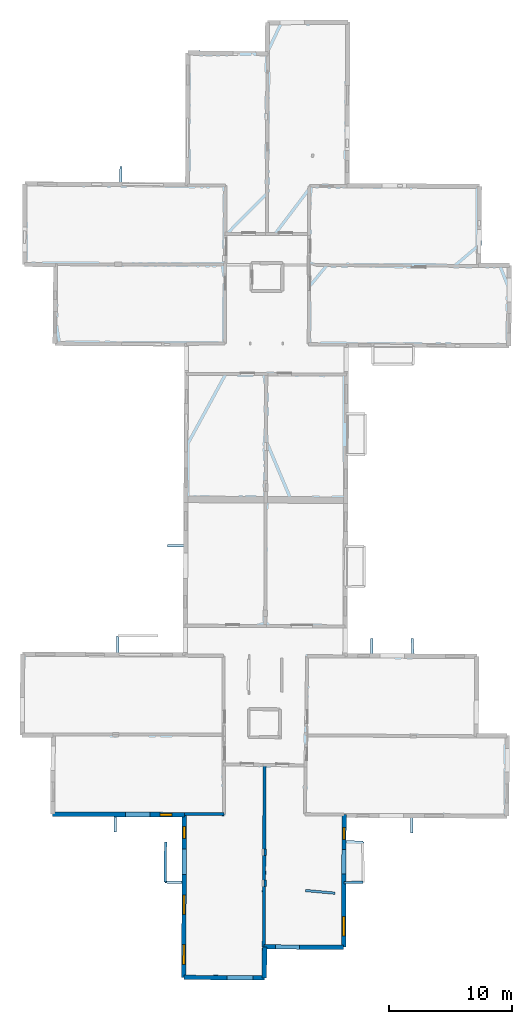
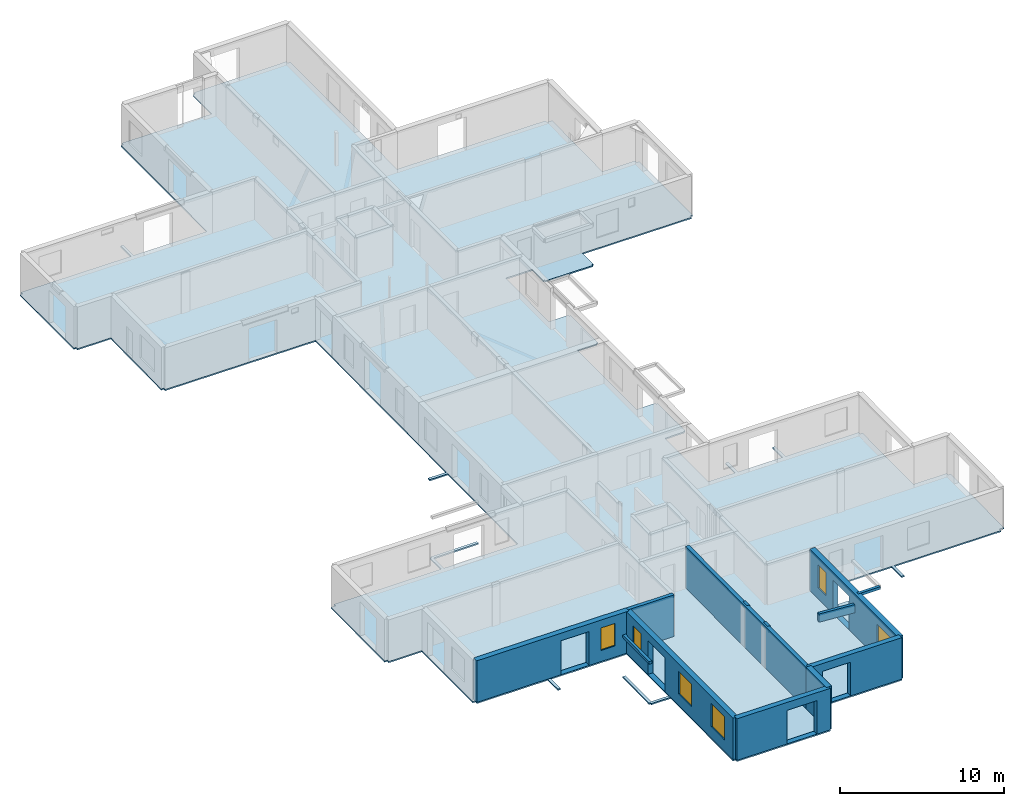
# One storey, part 3 of 15: 13 walls, 6 windows, 1 slab, 11 openings.
"""IFC2X3 building model written with IfcOpenShell, lengths in metres."""

from ifc_helpers import new_model, entity, si_unit, converted_unit, derived_unit, direction, frame, frame_2d, origin, origin_2d_with_axis, place, context, subcontext, project, spatial, polyline, rectangle, outline, extrude, source, transform, mapped, material, layer, layer_set, layer_usage, type_object, type_shapes, element, fill, save


model = new_model("IFC2X3")

# Units and contexts
model_context = context("Model", 3, precision=1e-05, world=origin(), true_north=direction((0.0, 1.0)))
body_context = subcontext(model_context, "Body", "Model", "MODEL_VIEW")
ifc_project = project(units=[si_unit("LENGTHUNIT", "METRE"), si_unit("AREAUNIT", "SQUARE_METRE"), si_unit("VOLUMEUNIT", "CUBIC_METRE"), converted_unit("PLANEANGLEUNIT", "DEGREE", entity("IfcRatioMeasure", 0.0174532925199433), si_unit("PLANEANGLEUNIT", "RADIAN"), dimensions=[0, 0, 0, 0, 0, 0, 0]), si_unit("MASSUNIT", "GRAM", prefix="KILO"), derived_unit("MASSDENSITYUNIT", [(si_unit("MASSUNIT", "GRAM", prefix="KILO"), 1), (si_unit("LENGTHUNIT", "METRE"), -3)]), derived_unit("MOMENTOFINERTIAUNIT", [(si_unit("LENGTHUNIT", "METRE"), 4)]), si_unit("TIMEUNIT", "SECOND"), si_unit("FREQUENCYUNIT", "HERTZ"), si_unit("THERMODYNAMICTEMPERATUREUNIT", "DEGREE_CELSIUS"), derived_unit("THERMALTRANSMITTANCEUNIT", [(si_unit("MASSUNIT", "GRAM", prefix="KILO"), 1), (si_unit("THERMODYNAMICTEMPERATUREUNIT", "KELVIN"), -1), (si_unit("TIMEUNIT", "SECOND"), -3)]), derived_unit("VOLUMETRICFLOWRATEUNIT", [(si_unit("LENGTHUNIT", "METRE"), 3), (si_unit("TIMEUNIT", "SECOND"), -1)]), si_unit("ELECTRICCURRENTUNIT", "AMPERE"), si_unit("ELECTRICVOLTAGEUNIT", "VOLT"), si_unit("POWERUNIT", "WATT"), si_unit("FORCEUNIT", "NEWTON", prefix="KILO"), si_unit("ILLUMINANCEUNIT", "LUX"), si_unit("LUMINOUSFLUXUNIT", "LUMEN"), si_unit("LUMINOUSINTENSITYUNIT", "CANDELA"), derived_unit("USERDEFINED", [(si_unit("MASSUNIT", "GRAM", prefix="KILO"), -1), (si_unit("LENGTHUNIT", "METRE"), -2), (si_unit("TIMEUNIT", "SECOND"), 3), (si_unit("LUMINOUSFLUXUNIT", "LUMEN"), 1)]), derived_unit("LINEARVELOCITYUNIT", [(si_unit("LENGTHUNIT", "METRE"), 1), (si_unit("TIMEUNIT", "SECOND"), -1)]), si_unit("PRESSUREUNIT", "PASCAL"), derived_unit("USERDEFINED", [(si_unit("LENGTHUNIT", "METRE"), -2), (si_unit("MASSUNIT", "GRAM", prefix="KILO"), 1), (si_unit("TIMEUNIT", "SECOND"), -2)]), derived_unit("LINEARFORCEUNIT", [(si_unit("MASSUNIT", "GRAM", prefix="KILO"), 1), (si_unit("LENGTHUNIT", "METRE"), 1), (si_unit("TIMEUNIT", "SECOND"), -2), (si_unit("LENGTHUNIT", "METRE"), -1)]), derived_unit("PLANARFORCEUNIT", [(si_unit("MASSUNIT", "GRAM", prefix="KILO"), 1), (si_unit("LENGTHUNIT", "METRE"), 1), (si_unit("TIMEUNIT", "SECOND"), -2), (si_unit("LENGTHUNIT", "METRE"), -2)])], contexts=[model_context])

# Site, building, storey
placement_1 = place(None, origin())
site = spatial("IfcSite", under=ifc_project, at=placement_1, CompositionType="ELEMENT")
building = spatial("IfcBuilding", under=site, at=placement_1, CompositionType="ELEMENT")
storey_placement = place(placement_1, frame((0.0, 0.0, 2.3807327747345)))
storey = spatial("IfcBuildingStorey", under=building, at=storey_placement, Name="Level 2", CompositionType="ELEMENT", Elevation=2.3807327747345)

# Slab
ifc_material_1 = material(Name="Floor default")
ifc_layer_1 = layer(ifc_material_1, 0.1)
ifc_layer_set_1 = layer_set([ifc_layer_1], Name="Floor : 100mm")
ifc_layer_usage_1 = layer_usage(ifc_layer_set_1, "AXIS3", "POSITIVE", 0.0)
slab_type = type_object("IfcSlabType", Name="Floor : 100mm", PredefinedType="FLOOR")
slab_placement = place(storey_placement, origin())
element("IfcSlab", 1, at=slab_placement, inside=storey, type_object=slab_type, material=ifc_layer_usage_1, Name="Floor : 100mm", ObjectType="Floor : 100mm", PredefinedType="FLOOR", context=body_context, shape_type="SweptSolid", body=[
    extrude(outline(polyline([(-13.683331489563, 19.4474563598633), (-13.5033340454102, 19.4465980529785), (-13.5040082931519, 19.2665996551514), (-11.1743402481079, 19.2578716278076), (-11.2043762207031, 13.0245876312256), (-11.0243797302246, 13.023720741272), (-11.0250949859619, 12.833722114563), (-6.06487083435059, 12.8150625228882), (-6.06035614013672, 11.5717830657959), (-5.8603572845459, 11.572509765625), (-5.86486625671387, 12.8143100738525), (-0.51823616027832, 12.7941980361938), (-0.535752296447754, 7.60072088241577), (-1.79068851470947, 7.61459493637085), (-1.76200675964355, 10.7753887176514), (-1.96199798583984, 10.7772035598755), (-1.99158573150635, 7.51661109924316), (-1.8915901184082, 7.5157036781311), (-1.89269542694092, 7.41570997238159), (-0.536426544189453, 7.40071582794189), (-0.562169075012207, -0.232175529003143), (-0.382170677185059, -0.232782408595085), (-0.383003234863281, -0.412778675556183), (6.16565418243408, -0.443077743053436), (6.16648769378662, -0.263079524040222), (6.35148525238037, -0.263790488243103), (6.36043262481689, 2.06458950042725), (12.6045618057251, 2.03753018379211), (12.6053419113159, 2.21752667427063), (12.7853422164917, 2.21702480316162), (12.7997140884399, 7.37378740310669), (14.1824331283569, 7.38224840164185), (14.1818227767944, 7.48224592208862), (14.2818212509155, 7.48271894454956), (14.2663774490356, 10.74733543396), (14.1663789749146, 10.746862411499), (14.1691541671753, 10.8468246459961), (12.8094987869263, 10.8845558166504), (12.8146600723267, 12.7366809844971), (18.0459899902344, 12.7129278182983), (18.0380744934082, 11.4866056442261), (18.2380714416504, 11.485315322876), (18.2459869384766, 12.7120199203491), (25.7083015441895, 12.6781377792358), (25.7091217041016, 12.8581981658936), (26.0352439880371, 12.8565711975098), (26.0678863525391, 19.4015102386475), (25.8828926086426, 19.4024314880371), (25.8830604553223, 19.5874309539795), (23.5625038146973, 19.5895538330078), (23.5972633361816, 25.8405075073242), (23.4122657775879, 25.8415374755859), (23.413200378418, 26.0265350341797), (18.2958908081055, 26.0524444580078), (18.2884140014648, 27.2836627960205), (18.0884170532227, 27.2824478149414), (18.0958786010742, 26.0534572601318), (14.9772272109985, 26.0692462921143), (14.9765844345093, 27.2774982452393), (14.7765836715698, 27.2773914337158), (14.7772283554077, 26.0702590942383), (12.8968343734741, 26.0797786712646), (12.920298576355, 31.3717422485352), (14.2845964431763, 31.3827095031738), (14.2837934494019, 31.4827060699463), (14.3837919235229, 31.4834098815918), (14.3604516983032, 34.797779083252), (14.2604532241821, 34.7970733642578), (14.2600698471069, 34.8970718383789), (12.9359064102173, 34.8920021057129), (12.9680185317993, 42.133918762207), (14.3412618637085, 42.1159324645996), (14.3425722122192, 42.2159233093262), (14.442572593689, 42.2158813476562), (14.4439916610718, 45.5327644348145), (14.3439950942993, 45.5328063964844), (14.3436155319214, 45.6328125), (12.9835062026978, 45.6276397705078), (12.9977788925171, 48.8461418151855), (13.007025718689, 50.9318580627441), (14.8728036880493, 50.9234886169434), (14.8559637069702, 49.575439453125), (14.9559564590454, 49.5741882324219), (14.9553594589233, 49.4741859436035), (18.269172668457, 49.4544067382812), (18.2697677612305, 49.5544090270996), (18.3697662353516, 49.553638458252), (18.3801879882812, 50.9077529907227), (26.0148010253906, 50.8735008239746), (26.0156097412109, 51.0534973144531), (26.2006034851074, 51.0524139404297), (26.2390289306641, 57.6010971069336), (26.0540351867676, 57.602180480957), (26.0547752380371, 57.7871742248535), (23.7570877075195, 57.7963638305664), (23.7646522521973, 58.5574226379395), (23.7663040161133, 58.5573997497559), (23.791877746582, 60.4229850769043), (23.7831954956055, 60.4231033325195), (23.8188247680664, 64.0079650878906), (23.448844909668, 64.0116424560547), (23.4448013305664, 64.1959609985352), (13.0637731552124, 64.259391784668), (13.1224775314331, 77.3386840820312), (12.9374780654907, 77.3395156860352), (12.9364728927612, 77.5195159912109), (6.40840244293213, 77.4830322265625), (6.40940952301025, 77.3030319213867), (6.23441028594971, 77.3036270141602), (6.22640895843506, 74.9720764160156), (5.34152507781982, 74.980339050293), (5.34094333648682, 74.9181442260742), (5.22008609771729, 74.9949645996094), (5.16644382476807, 74.9105758666992), (5.1667947769165, 74.9855728149414), (-0.0517759323120117, 75.0307464599609), (-0.0535049438476562, 74.8457641601562), (-0.228504180908203, 74.8463668823242), (-0.264826774597168, 64.3250885009766), (-5.39295291900635, 64.3531494140625), (-5.38068675994873, 65.6215591430664), (-5.5806770324707, 65.6234970092773), (-5.59295177459717, 64.354248046875), (-13.2946186065674, 64.3963928222656), (-13.2956304550171, 64.2113876342773), (-13.4656295776367, 64.2116012573242), (-13.4739418029785, 57.6495895385742), (-13.3039407730103, 57.6493721008301), (-13.30491065979, 57.4843864440918), (-10.9719734191895, 57.4706726074219), (-11.0287570953369, 51.2353248596191), (-10.8537635803223, 51.2337303161621), (-10.854681968689, 51.068733215332), (-0.319339752197266, 51.010082244873), (-0.414472579956055, 34.9214935302734), (-1.69244766235352, 34.9278869628906), (-1.69344806671143, 34.7278900146484), (-0.415655136108398, 34.7215003967285), (-0.466342926025391, 26.1492118835449), (-5.62951374053955, 26.1689796447754), (-5.63559913635254, 27.4110736846924), (-2.47951793670654, 27.4197387695312), (-2.48006725311279, 27.6197376251221), (-5.73636388778687, 27.6107978820801), (-5.73608922958374, 27.5107975006104), (-5.83608818054199, 27.5103073120117), (-5.8295202255249, 26.1697444915771), (-13.3383483886719, 26.1984901428223), (-13.339056968689, 26.0133647918701), (-13.6520252227783, 26.014856338501), (-13.683331489563, 19.4474563598633)])), frame((0.0, 0.0, -0.1), z_axis=(0.0, 0.0, 1.0), x_axis=(1.0, 0.0, 0.0)), (0.0, 0.0, 1.0), 0.1),
])

# Walls
ifc_material_2 = material(Name="Default wall")
ifc_layer_2 = layer(ifc_material_2, 0.25)
ifc_layer_set_2 = layer_set([ifc_layer_2], Name="wall_thickness_0.2500")
ifc_layer_usage_2 = layer_usage(ifc_layer_set_2, "AXIS2", "POSITIVE", -0.125)
wall_type_1 = type_object("IfcWallType", Name="wall_thickness_0.2500", PredefinedType="STANDARD", material=ifc_layer_set_2)
wall_1_placement = place(storey_placement, frame((-0.337405809508595, 13.0402561064376, 0.0), z_axis=(0.0, 0.0, 1.0), x_axis=(0.99998789077311, -0.00492120992706382, 0.0)))
element("IfcWallStandardCase", 2, at=wall_1_placement, inside=storey, type_object=wall_type_1, material=ifc_layer_usage_2, Name="Wall:817", ObjectType="Wall", context=body_context, shape_type="SweptSolid", body=[
    extrude(outline(polyline([(3.21301476676684, -0.125), (3.21301476676684, 0.125), (0.0, 0.125), (0.0, -0.125), (3.21301476676684, -0.125)])), origin(), (0.0, 0.0, 1.0), 3.08589615821838),
])
ifc_layer_3 = layer(ifc_material_2, 0.2)
ifc_layer_set_3 = layer_set([ifc_layer_3], Name="wall_thickness_0.2000")
ifc_layer_usage_3 = layer_usage(ifc_layer_set_3, "AXIS2", "POSITIVE", -0.1)
wall_type_2 = type_object("IfcWallType", Name="wall_thickness_0.2000", PredefinedType="STANDARD", material=ifc_layer_set_3)
placement_2 = place(placement_1, frame((0.0, 0.0, 4.8560004234314)))
wall_2_placement = place(placement_2, frame((9.50520270055505, 6.82234630754477, 0.0), z_axis=(0.0, 0.0, 1.0), x_axis=(0.995889679120745, -0.0905745384795281, 0.0)))
element("IfcWallStandardCase", 3, at=wall_2_placement, inside=storey, type_object=wall_type_2, material=ifc_layer_usage_3, Name="Wall:696", ObjectType="Wall", context=body_context, shape_type="SweptSolid", body=[
    extrude(outline(polyline([(2.4005655275322, -0.1), (2.4005655275322, 0.1), (0.0, 0.1), (0.0, -0.1), (2.4005655275322, -0.1)])), origin(), (0.0, 0.0, 1.0), 0.610628509521485),
])
wall_3_placement = place(storey_placement, frame((6.23772610286101, 10.2010949448322, 0.0), z_axis=(0.0, 0.0, 1.0), x_axis=(-0.00754673896411261, -0.999971522960033, 0.0)))
element("IfcWallStandardCase", 4, at=wall_3_placement, inside=storey, type_object=wall_type_2, material=ifc_layer_usage_3, Name="Wall:700", ObjectType="Wall", context=body_context, shape_type="SweptSolid", body=[
    extrude(outline(polyline([(0.525000263869024, -0.1), (0.525000263869024, 0.1), (0.0, 0.1), (0.0, -0.1), (0.525000263869024, -0.1)])), origin(), (0.0, 0.0, 1.0), 3.08589615821838),
])
wall_4_placement = place(storey_placement, frame((6.22050848009092, 7.6675029171327, 0.0), z_axis=(0.0, 0.0, 1.0), x_axis=(-1.94438503231201e-05, -0.999999999810968, 0.0)))
element("IfcWallStandardCase", 5, at=wall_4_placement, inside=storey, type_object=wall_type_2, material=ifc_layer_usage_3, Name="Wall:738", ObjectType="Wall", context=body_context, shape_type="SweptSolid", body=[
    extrude(outline(polyline([(0.514999866582947, -0.1), (0.514999866582947, 0.1), (0.0, 0.1), (0.0, -0.1), (0.514999866582947, -0.1)])), origin(), (0.0, 0.0, 1.0), 3.08589615821838),
])
placement_3 = place(placement_1, frame((0.0, 0.0, 5.26399993896484)))
wall_5_placement = place(placement_3, frame((12.6199880978985, 7.47268902126731, 0.0), z_axis=(0.0, 0.0, 1.0), x_axis=(0.999981276077077, 0.00611943586125221, 0.0)))
element("IfcWallStandardCase", 6, at=wall_5_placement, inside=storey, type_object=wall_type_2, material=ifc_layer_usage_3, Name="Wall:760", ObjectType="Wall", context=body_context, shape_type="SweptSolid", body=[
    extrude(outline(polyline([(1.56186357954043, -0.1), (1.56186357954043, 0.1), (0.0, 0.1), (0.0, -0.1), (1.56186357954043, -0.1)])), origin(), (0.0, 0.0, 1.0), 0.202628993988037),
])
placement_4 = place(placement_1, frame((0.0, 0.0, 5.26399993896484)))
wall_6_placement = place(placement_4, frame((-1.86200240430845, 10.7762961130208, 0.0), z_axis=(0.0, 0.0, 1.0), x_axis=(-0.00907397287940236, -0.999958830660635, 0.0)))
element("IfcWallStandardCase", 7, at=wall_6_placement, inside=storey, type_object=wall_type_2, material=ifc_layer_usage_3, Name="Wall:768", ObjectType="Wall", context=body_context, shape_type="SweptSolid", body=[
    extrude(outline(polyline([(3.26072670259652, -0.1), (3.26072670259652, 0.1), (0.0, 0.1), (0.0, -0.1), (3.26072670259652, -0.1)])), origin(), (0.0, 0.0, 1.0), 0.202628993988037),
])
ifc_layer_4 = layer(ifc_material_2, 0.259999990463257)
ifc_layer_set_4 = layer_set([ifc_layer_4], Name="wall_thickness_0.2600")
ifc_layer_usage_4 = layer_usage(ifc_layer_set_4, "AXIS2", "POSITIVE", -0.129999995231628)
wall_type_3 = type_object("IfcWallType", Name="wall_thickness_0.2600", PredefinedType="STANDARD", material=ifc_layer_set_4)
wall_7_placement = place(storey_placement, frame((6.17706231490227, 17.0238505403375, 0.0), z_axis=(0.0, 0.0, 1.0), x_axis=(-0.00398271798372855, -0.99999206894728, 0.0)))
element("IfcWallStandardCase", 8, at=wall_7_placement, inside=storey, type_object=wall_type_3, material=ifc_layer_usage_4, Name="Wall:832", ObjectType="Wall", context=body_context, shape_type="SweptSolid", body=[
    extrude(outline(polyline([(14.7783292781737, -0.129999995231628), (14.7783292781737, 0.129999995231628), (0.0, 0.129999995231628), (0.0, -0.129999995231628), (14.7783292781737, -0.129999995231628)])), origin(), (0.0, 0.0, 1.0), 3.08589615821838),
])

# Wall, openings, window
ifc_layer_5 = layer(ifc_material_2, 0.379999995231628)
ifc_layer_set_5 = layer_set([ifc_layer_5], Name="wall_thickness_0.3800")
ifc_layer_usage_5 = layer_usage(ifc_layer_set_5, "AXIS2", "POSITIVE", -0.189999997615814)
wall_type_4 = type_object("IfcWallType", Name="wall_thickness_0.3800", PredefinedType="STANDARD", material=ifc_layer_set_5)
wall_8_placement = place(storey_placement, frame((-11.0243802465657, 13.0237207678256, 0.0), z_axis=(0.0, 0.0, 1.0), x_axis=(0.999992924630831, -0.00376174005980669, 0.0)))
wall_8 = element("IfcWallStandardCase", 9, at=wall_8_placement, inside=storey, type_object=wall_type_4, material=ifc_layer_usage_5, Name="Wall:725", ObjectType="Wall", context=body_context, shape_type="SweptSolid", body=[
    extrude(outline(polyline([(10.6868594040639, -0.189999997615814), (10.6868594040639, 0.189999997615814), (0.0, 0.189999997615814), (0.0, -0.189999997615814), (10.6868594040639, -0.189999997615814)])), origin(), (0.0, 0.0, 1.0), 3.08589615821838),
])
opening_1_placement = place(wall_8_placement, frame((5.90762836633177, -0.189999997615814, 0.00526785850524902)))
element("IfcOpeningElement", 10, at=opening_1_placement, cuts=wall_8, Name="Opening : 1975 x 2520 : 460", ObjectType="Opening", context=body_context, shape_type="SweptSolid", body=[
    extrude(rectangle(XDim=1.975, YDim=2.52, at=frame_2d((1.26, 0.9875), x_axis=(0.0, 1.0))), frame((0.0, 0.0, 0.0), z_axis=(0.0, 1.0, 0.0), x_axis=(0.0, 0.0, 1.0)), (0.0, 0.0, 1.0), 0.379999995231628),
])
opening_2_placement = place(wall_8_placement, frame((8.71262872472741, -0.189999997615814, 0.825267791748047)))
opening_2 = element("IfcOpeningElement", 11, at=opening_2_placement, cuts=wall_8, Name="Opening : 980 x 1675 : 461", ObjectType="Opening", context=body_context, shape_type="SweptSolid", body=[
    extrude(rectangle(XDim=0.98, YDim=1.675, at=frame_2d((0.8375, 0.49), x_axis=(0.0, 1.0))), frame((0.0, 0.0, 0.0), z_axis=(0.0, 1.0, 0.0), x_axis=(0.0, 0.0, 1.0)), (0.0, 0.0, 1.0), 0.379999995231628),
])
ifc_material_3 = material(Name="Window Default")
window_style_1 = type_object("IfcWindowStyle", Name="Window : 980 x 1675mm", ConstructionType="NOTDEFINED", OperationType="NOTDEFINED", ParameterTakesPrecedence=False, Sizeable=False, material=ifc_material_3)
shared_shape_1 = source(origin(), body_context, "Body", "SweptSolid", [
    extrude(rectangle(XDim=0.189999997615814, YDim=0.98, at=origin_2d_with_axis()), frame((0.49, 0.189999997615814, 0.0), z_axis=(0.0, 0.0, 1.0), x_axis=(0.0, 1.0, 0.0)), (0.0, 0.0, 1.0), 1.675),
])
type_shapes(window_style_1, [shared_shape_1])
window_1_placement = place(opening_2_placement, origin())
window_1 = element("IfcWindow", 12, at=window_1_placement, inside=storey, type_object=window_style_1, Name="Window : 980 x 1675mm : 250", ObjectType="Window : 980 x 1675mm", OverallHeight=1.675, OverallWidth=0.98, context=body_context, shape_type="MappedRepresentation", body=[
    mapped(shared_shape_1, transform((0.0, 0.0, 0.0), scale=1.0)),
])
fill(opening_2, window_1)

# Wall
ifc_layer_6 = layer(ifc_material_2, 0.370000004768372)
ifc_layer_set_6 = layer_set([ifc_layer_6], Name="wall_thickness_0.3700")
ifc_layer_usage_6 = layer_usage(ifc_layer_set_6, "AXIS2", "POSITIVE", -0.185000002384186)
wall_type_5 = type_object("IfcWallType", Name="wall_thickness_0.3700", PredefinedType="STANDARD", material=ifc_layer_set_6)
wall_9_placement = place(storey_placement, frame((6.17612730985899, 2.24538947656472, 0.0), z_axis=(0.0, 0.0, 1.0), x_axis=(-0.00384284951023051, -0.999992616226561, 0.0)))
element("IfcWallStandardCase", 13, at=wall_9_placement, inside=storey, type_object=wall_type_5, material=ifc_layer_usage_6, Name="Wall:749", ObjectType="Wall", context=body_context, shape_type="SweptSolid", body=[
    extrude(outline(polyline([(2.50848750766099, -0.185000002384186), (2.50848750766099, 0.185000002384186), (0.0, 0.185000002384186), (0.0, -0.185000002384186), (2.50848750766099, -0.185000002384186)])), origin(), (0.0, 0.0, 1.0), 3.08589615821838),
])

# Wall, opening
ifc_layer_7 = layer(ifc_material_2, 0.360000014305115)
ifc_layer_set_7 = layer_set([ifc_layer_7], Name="wall_thickness_0.3600")
ifc_layer_usage_7 = layer_usage(ifc_layer_set_7, "AXIS2", "POSITIVE", -0.180000007152557)
wall_type_6 = type_object("IfcWallType", Name="wall_thickness_0.3600", PredefinedType="STANDARD", material=ifc_layer_set_7)
wall_10_placement = place(storey_placement, frame((6.11820403709709, 2.24564091232374, 0.0), z_axis=(0.0, 0.0, 1.0), x_axis=(0.999990610254009, -0.0043335209488656, 0.0)))
wall_10 = element("IfcWallStandardCase", 14, at=wall_10_placement, inside=storey, type_object=wall_type_6, material=ifc_layer_usage_7, Name="Wall:743", ObjectType="Wall", context=body_context, shape_type="SweptSolid", body=[
    extrude(outline(polyline([(6.48719870764269, -0.180000007152557), (6.48719870764269, 0.180000007152557), (0.0, 0.180000007152557), (0.0, -0.180000007152557), (6.48719870764269, -0.180000007152557)])), origin(), (0.0, 0.0, 1.0), 3.08589615821838),
])
opening_3_placement = place(wall_10_placement, frame((0.935078825836557, -0.180000007152557, 0.00526785850524902)))
element("IfcOpeningElement", 15, at=opening_3_placement, cuts=wall_10, Name="Opening : 1970 x 2505 : 476", ObjectType="Opening", context=body_context, shape_type="SweptSolid", body=[
    extrude(rectangle(XDim=1.97, YDim=2.505, at=frame_2d((1.2525, 0.985), x_axis=(0.0, 1.0))), frame((0.0, 0.0, 0.0), z_axis=(0.0, 1.0, 0.0), x_axis=(0.0, 0.0, 1.0)), (0.0, 0.0, 1.0), 0.360000014305115),
])

# Wall, openings, windows
wall_11_placement = place(storey_placement, frame((12.6353464561694, 12.9827662136396, 0.0), z_axis=(0.0, 0.0, 1.0), x_axis=(-0.00278715435924839, -0.999996115877746, 0.0)))
wall_11 = element("IfcWallStandardCase", 16, at=wall_11_placement, inside=storey, type_object=wall_type_6, material=ifc_layer_usage_7, Name="Wall:778", ObjectType="Wall", context=body_context, shape_type="SweptSolid", body=[
    extrude(outline(polyline([(10.7652815292457, -0.180000007152557), (10.7652815292457, 0.180000007152557), (0.0, 0.180000007152557), (0.0, -0.180000007152557), (10.7652815292457, -0.180000007152557)])), origin(), (0.0, 0.0, 1.0), 3.08589615821838),
])
opening_4_placement = place(wall_11_placement, frame((2.83775002151901, -0.180000007152557, 0.00526785850524902)))
element("IfcOpeningElement", 17, at=opening_4_placement, cuts=wall_11, Name="Opening : 1980 x 2480 : 490", ObjectType="Opening", context=body_context, shape_type="SweptSolid", body=[
    extrude(rectangle(XDim=1.98, YDim=2.48, at=frame_2d((1.24, 0.99), x_axis=(0.0, 1.0))), frame((0.0, 0.0, 0.0), z_axis=(0.0, 1.0, 0.0), x_axis=(0.0, 0.0, 1.0)), (0.0, 0.0, 1.0), 0.360000014305115),
])
opening_5_placement = place(wall_11_placement, frame((1.02275006562117, -0.180000007152557, 0.805267810821533)))
opening_5 = element("IfcOpeningElement", 18, at=opening_5_placement, cuts=wall_11, Name="Opening : 990 x 1725 : 491", ObjectType="Opening", context=body_context, shape_type="SweptSolid", body=[
    extrude(rectangle(XDim=0.99, YDim=1.725, at=frame_2d((0.8625, 0.495), x_axis=(0.0, 1.0))), frame((0.0, 0.0, 0.0), z_axis=(0.0, 1.0, 0.0), x_axis=(0.0, 0.0, 1.0)), (0.0, 0.0, 1.0), 0.360000014305115),
])
opening_6_placement = place(wall_11_placement, frame((8.25774921476041, -0.180000007152557, 0.805267810821533)))
opening_6 = element("IfcOpeningElement", 19, at=opening_6_placement, cuts=wall_11, Name="Opening : 1580 x 1705 : 492", ObjectType="Opening", context=body_context, shape_type="SweptSolid", body=[
    extrude(rectangle(XDim=1.58, YDim=1.705, at=frame_2d((0.8525, 0.79), x_axis=(0.0, 1.0))), frame((0.0, 0.0, 0.0), z_axis=(0.0, 1.0, 0.0), x_axis=(0.0, 0.0, 1.0)), (0.0, 0.0, 1.0), 0.360000014305115),
])
window_style_2 = type_object("IfcWindowStyle", Name="Window : 990 x 1725mm", ConstructionType="NOTDEFINED", OperationType="NOTDEFINED", ParameterTakesPrecedence=False, Sizeable=False, material=ifc_material_3)
shared_shape_2 = source(origin(), body_context, "Body", "SweptSolid", [
    extrude(rectangle(XDim=0.180000007152557, YDim=0.99, at=origin_2d_with_axis()), frame((0.495, 0.180000007152557, 0.0), z_axis=(0.0, 0.0, 1.0), x_axis=(0.0, 1.0, 0.0)), (0.0, 0.0, 1.0), 1.725),
])
type_shapes(window_style_2, [shared_shape_2])
window_2_placement = place(opening_5_placement, origin())
window_2 = element("IfcWindow", 20, at=window_2_placement, inside=storey, type_object=window_style_2, Name="Window : 990 x 1725mm : 263", ObjectType="Window : 990 x 1725mm", OverallHeight=1.725, OverallWidth=0.99, context=body_context, shape_type="MappedRepresentation", body=[
    mapped(shared_shape_2, transform((0.0, 0.0, 0.0), scale=1.0)),
])
fill(opening_5, window_2)
window_style_3 = type_object("IfcWindowStyle", Name="Window : 1580 x 1705mm", ConstructionType="NOTDEFINED", OperationType="NOTDEFINED", ParameterTakesPrecedence=False, Sizeable=False, material=ifc_material_3)
shared_shape_3 = source(origin(), body_context, "Body", "SweptSolid", [
    extrude(rectangle(XDim=0.180000007152557, YDim=1.58, at=origin_2d_with_axis()), frame((0.79, 0.180000007152557, 0.0), z_axis=(0.0, 0.0, 1.0), x_axis=(0.0, 1.0, 0.0)), (0.0, 0.0, 1.0), 1.705),
])
type_shapes(window_style_3, [shared_shape_3])
window_3_placement = place(opening_6_placement, origin())
window_3 = element("IfcWindow", 21, at=window_3_placement, inside=storey, type_object=window_style_3, Name="Window : 1580 x 1705mm : 264", ObjectType="Window : 1580 x 1705mm", OverallHeight=1.705, OverallWidth=1.58, context=body_context, shape_type="MappedRepresentation", body=[
    mapped(shared_shape_3, transform((0.0, 0.0, 0.0), scale=1.0)),
])
fill(opening_6, window_3)

wall_12_placement = place(storey_placement, frame((-0.337405334406987, 13.0402569221697, 0.0), z_axis=(0.0, 0.0, 1.0), x_axis=(-0.003372606667929, -0.999994312745959, 0.0)))
wall_12 = element("IfcWallStandardCase", 22, at=wall_12_placement, inside=storey, type_object=wall_type_6, material=ifc_layer_usage_7, Name="Wall:809", ObjectType="Wall", context=body_context, shape_type="SweptSolid", body=[
    extrude(outline(polyline([(13.2731148285488, -0.180000007152557), (13.2731148285488, 0.180000007152557), (0.0, 0.180000007152557), (0.0, -0.180000007152557), (13.2731148285488, -0.180000007152557)])), origin(), (0.0, 0.0, 1.0), 3.08589615821838),
])
opening_7_placement = place(wall_12_placement, frame((2.84912680765058, -0.180000007152557, 0.00526785850524902)))
element("IfcOpeningElement", 23, at=opening_7_placement, cuts=wall_12, Name="Opening : 2065 x 2510 : 514", ObjectType="Opening", context=body_context, shape_type="SweptSolid", body=[
    extrude(rectangle(XDim=2.065, YDim=2.51, at=frame_2d((1.255, 1.0325), x_axis=(0.0, 1.0))), frame((0.0, 0.0, 0.0), z_axis=(0.0, 1.0, 0.0), x_axis=(0.0, 0.0, 1.0)), (0.0, 0.0, 1.0), 0.360000014305115),
])
opening_8_placement = place(wall_12_placement, frame((10.6013502808113, -0.180000007152557, 0.830267667770386)))
opening_8 = element("IfcOpeningElement", 24, at=opening_8_placement, cuts=wall_12, Name="Opening : 1605 x 1710 : 515", ObjectType="Opening", context=body_context, shape_type="SweptSolid", body=[
    extrude(rectangle(XDim=1.605, YDim=1.71, at=frame_2d((0.855, 0.8025), x_axis=(0.0, 1.0))), frame((0.0, 0.0, 0.0), z_axis=(0.0, 1.0, 0.0), x_axis=(0.0, 0.0, 1.0)), (0.0, 0.0, 1.0), 0.360000014305115),
])
opening_9_placement = place(wall_12_placement, frame((6.59634908495851, -0.180000007152557, 0.830267667770386)))
opening_9 = element("IfcOpeningElement", 25, at=opening_9_placement, cuts=wall_12, Name="Opening : 1565 x 1680 : 516", ObjectType="Opening", context=body_context, shape_type="SweptSolid", body=[
    extrude(rectangle(XDim=1.565, YDim=1.68, at=frame_2d((0.84, 0.7825), x_axis=(0.0, 1.0))), frame((0.0, 0.0, 0.0), z_axis=(0.0, 1.0, 0.0), x_axis=(0.0, 0.0, 1.0)), (0.0, 0.0, 1.0), 0.360000014305115),
])
opening_10_placement = place(wall_12_placement, frame((1.00634861181406, -0.180000007152557, 0.825267791748047)))
opening_10 = element("IfcOpeningElement", 26, at=opening_10_placement, cuts=wall_12, Name="Opening : 990 x 1670 : 517", ObjectType="Opening", context=body_context, shape_type="SweptSolid", body=[
    extrude(rectangle(XDim=0.99, YDim=1.67, at=frame_2d((0.835, 0.495), x_axis=(0.0, 1.0))), frame((0.0, 0.0, 0.0), z_axis=(0.0, 1.0, 0.0), x_axis=(0.0, 0.0, 1.0)), (0.0, 0.0, 1.0), 0.360000014305115),
])
window_style_4 = type_object("IfcWindowStyle", Name="Window : 1605 x 1710mm", ConstructionType="NOTDEFINED", OperationType="NOTDEFINED", ParameterTakesPrecedence=False, Sizeable=False, material=ifc_material_3)
shared_shape_4 = source(origin(), body_context, "Body", "SweptSolid", [
    extrude(rectangle(XDim=0.180000007152557, YDim=1.605, at=origin_2d_with_axis()), frame((0.8025, 0.180000007152557, 0.0), z_axis=(0.0, 0.0, 1.0), x_axis=(0.0, 1.0, 0.0)), (0.0, 0.0, 1.0), 1.71),
])
type_shapes(window_style_4, [shared_shape_4])
window_4_placement = place(opening_8_placement, origin())
window_4 = element("IfcWindow", 27, at=window_4_placement, inside=storey, type_object=window_style_4, Name="Window : 1605 x 1710mm : 276", ObjectType="Window : 1605 x 1710mm", OverallHeight=1.71, OverallWidth=1.605, context=body_context, shape_type="MappedRepresentation", body=[
    mapped(shared_shape_4, transform((0.0, 0.0, 0.0), scale=1.0)),
])
fill(opening_8, window_4)
window_style_5 = type_object("IfcWindowStyle", Name="Window : 1565 x 1680mm", ConstructionType="NOTDEFINED", OperationType="NOTDEFINED", ParameterTakesPrecedence=False, Sizeable=False, material=ifc_material_3)
shared_shape_5 = source(origin(), body_context, "Body", "SweptSolid", [
    extrude(rectangle(XDim=0.180000007152557, YDim=1.565, at=origin_2d_with_axis()), frame((0.7825, 0.180000007152557, 0.0), z_axis=(0.0, 0.0, 1.0), x_axis=(0.0, 1.0, 0.0)), (0.0, 0.0, 1.0), 1.68),
])
type_shapes(window_style_5, [shared_shape_5])
window_5_placement = place(opening_9_placement, origin())
window_5 = element("IfcWindow", 28, at=window_5_placement, inside=storey, type_object=window_style_5, Name="Window : 1565 x 1680mm : 277", ObjectType="Window : 1565 x 1680mm", OverallHeight=1.68, OverallWidth=1.565, context=body_context, shape_type="MappedRepresentation", body=[
    mapped(shared_shape_5, transform((0.0, 0.0, 0.0), scale=1.0)),
])
fill(opening_9, window_5)
window_style_6 = type_object("IfcWindowStyle", Name="Window : 990 x 1670mm", ConstructionType="NOTDEFINED", OperationType="NOTDEFINED", ParameterTakesPrecedence=False, Sizeable=False, material=ifc_material_3)
shared_shape_6 = source(origin(), body_context, "Body", "SweptSolid", [
    extrude(rectangle(XDim=0.180000007152557, YDim=0.99, at=origin_2d_with_axis()), frame((0.495, 0.180000007152557, 0.0), z_axis=(0.0, 0.0, 1.0), x_axis=(0.0, 1.0, 0.0)), (0.0, 0.0, 1.0), 1.67),
])
type_shapes(window_style_6, [shared_shape_6])
window_6_placement = place(opening_10_placement, origin())
window_6 = element("IfcWindow", 29, at=window_6_placement, inside=storey, type_object=window_style_6, Name="Window : 990 x 1670mm : 278", ObjectType="Window : 990 x 1670mm", OverallHeight=1.67, OverallWidth=0.99, context=body_context, shape_type="MappedRepresentation", body=[
    mapped(shared_shape_6, transform((0.0, 0.0, 0.0), scale=1.0)),
])
fill(opening_10, window_6)

# Wall, opening
wall_13_placement = place(storey_placement, frame((-0.382170428153955, -0.232780594988901, 0.0), z_axis=(0.0, 0.0, 1.0), x_axis=(0.999989296716872, -0.00462671067778345, 0.0)))
wall_13 = element("IfcWallStandardCase", 30, at=wall_13_placement, inside=storey, type_object=wall_type_6, material=ifc_layer_usage_7, Name="Wall:826", ObjectType="Wall", context=body_context, shape_type="SweptSolid", body=[
    extrude(outline(polyline([(6.54872751018203, -0.180000007152557), (6.54872751018203, 0.180000007152557), (0.0, 0.180000007152557), (0.0, -0.180000007152557), (6.54872751018203, -0.180000007152557)])), origin(), (0.0, 0.0, 1.0), 3.08589615821838),
])
opening_11_placement = place(wall_13_placement, frame((3.50383861120119, -0.180000007152557, 0.00726771354675293)))
element("IfcOpeningElement", 31, at=opening_11_placement, cuts=wall_13, Name="Opening : 2100 x 2490 : 525", ObjectType="Opening", context=body_context, shape_type="SweptSolid", body=[
    extrude(rectangle(XDim=2.1, YDim=2.49, at=frame_2d((1.245, 1.05), x_axis=(0.0, 1.0))), frame((0.0, 0.0, 0.0), z_axis=(0.0, 1.0, 0.0), x_axis=(0.0, 0.0, 1.0)), (0.0, 0.0, 1.0), 0.360000014305115),
])

save(model, "model.ifc")
